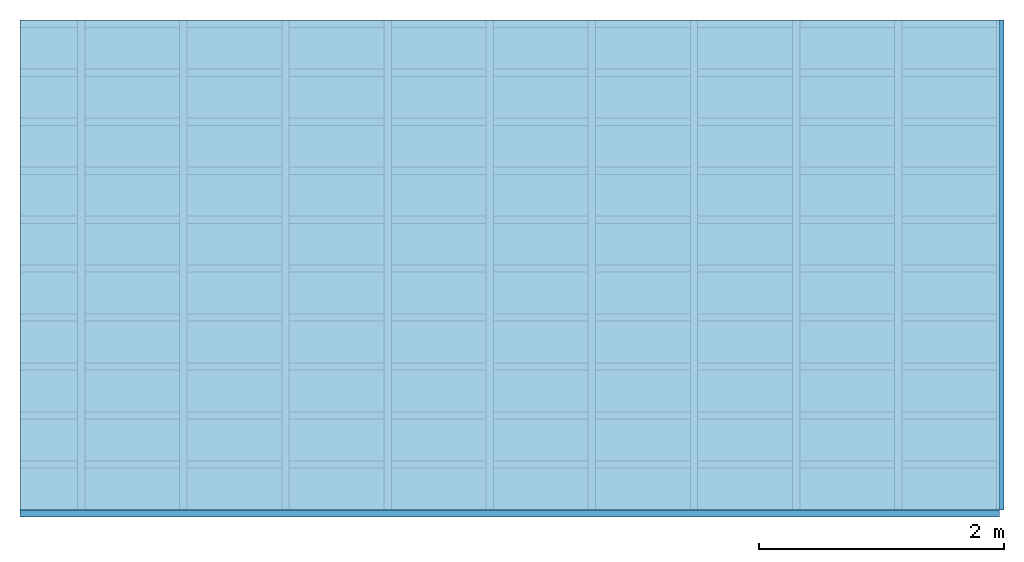
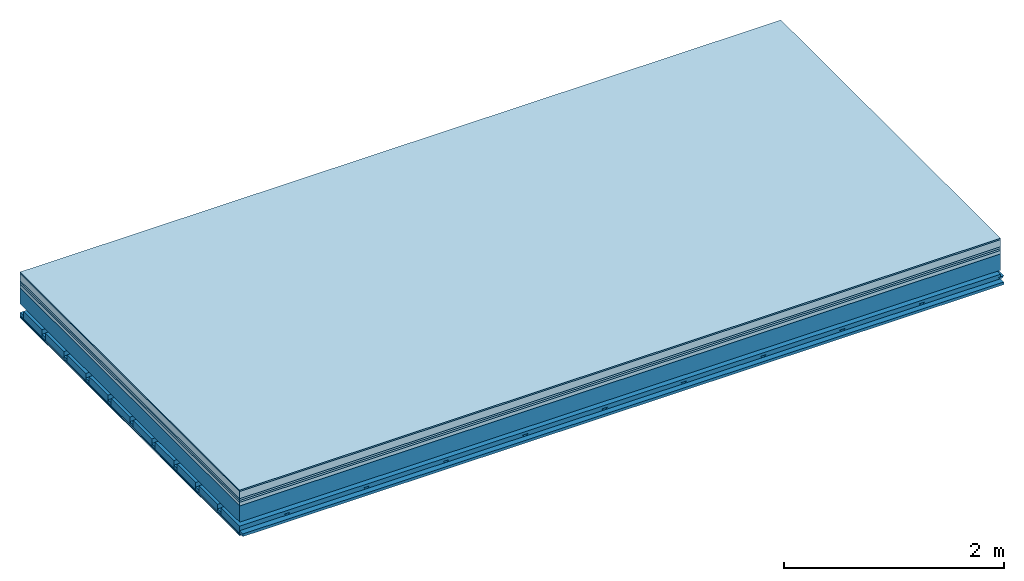
# One storey: 8 plates, 4 members, 1 element without a shape of its own.
"""IFC4 building model written with IfcOpenShell, lengths in metres."""

from ifc_helpers import new_model, si_unit, derived_unit, direction, frame, frame_2d, origin, origin_with_axes, place, context, project, spatial, polyline, rectangle, outline, extrude, material, layer, layer_set, type_object, element, aggregate, save


model = new_model("IFC4")

# Units and contexts
plan_context = context("Plan", 3, precision=1e-05, world=origin(), true_north=direction((0.0, 1.0)))
model_context = context("Model", 3, precision=1e-05, world=origin(), true_north=direction((0.0, 1.0)))
ifc_project = project(units=[si_unit("LENGTHUNIT", "METRE"), derived_unit("SOUNDPRESSUREUNIT", [(si_unit("PRESSUREUNIT", "PASCAL", prefix="MICRO"), 0)]), si_unit("ENERGYUNIT", "JOULE", prefix="MEGA"), si_unit("MASSUNIT", "GRAM", prefix="KILO"), derived_unit("THERMALTRANSMITTANCEUNIT", [(si_unit("POWERUNIT", "WATT"), 1), (si_unit("AREAUNIT", "SQUARE_METRE"), -1), (si_unit("THERMODYNAMICTEMPERATUREUNIT", "KELVIN"), -1)]), derived_unit("AREADENSITYUNIT", [(si_unit("MASSUNIT", "GRAM", prefix="KILO"), 1), (si_unit("AREAUNIT", "SQUARE_METRE"), -1)]), derived_unit("USERDEFINED", [(si_unit("ENERGYUNIT", "JOULE", prefix="MEGA"), 1), (si_unit("AREAUNIT", "SQUARE_METRE"), -1)])], contexts=[plan_context, model_context])

# Site, building, storey
site = spatial("IfcSite", under=ifc_project)
building_placement = place(None, origin())
building = spatial("IfcBuilding", under=site, at=building_placement)
storey_placement = place(building_placement, origin())
storey = spatial("IfcBuildingStorey", under=building, at=storey_placement)

# Slab, members, plates
ifc_material_1 = material(Category="11.013")
ifc_layer_1 = layer(ifc_material_1, 0.015, Name="Flooring")
ifc_material_2 = material(Name="Cement screed", Category="04.006")
ifc_layer_2 = layer(ifc_material_2, 0.08, Name="On-material")
ifc_material_3 = material(Name="Wood fiber generic product", Category="10.009")
ifc_layer_3 = layer(ifc_material_3, 0.02, Name="Impact sound insulation")
ifc_material_4 = material(Category="10.004")
ifc_layer_4 = layer(ifc_material_4, 0.02, Name="Additional insulation")
ifc_material_5 = material(Name="Garden plates", Category="02.007")
ifc_layer_5 = layer(ifc_material_5, 0.04, Name="on Supporting structure")
ifc_material_6 = material(Name="no composite action")
ifc_layer_6 = layer(ifc_material_6, 0.0, Name="Bond")
ifc_layer_7 = layer(None, 0.18, Name="Supporting structure")
ifc_layer_8 = layer(ifc_material_6, 0.0, Name="Bond")
ifc_layer_9 = layer(None, 0.095, Name="Coupling")
ifc_layer_10 = layer(None, 0.03, Name="Battens / profiles")
ifc_material_7 = material(Name="Plasterboard type A", Category="03.008")
ifc_layer_11 = layer(ifc_material_7, 0.0125, Name="Ceiling covering 1st layer")
ifc_layer_12 = layer(ifc_material_7, 0.0125, Name="Ceiling covering layer 2")
ifc_material_8 = material(Category="04.001")
ifc_layer_13 = layer(ifc_material_8, 0.003, Name="Surface / treatment")
ifc_layer_set = layer_set([ifc_layer_1, ifc_layer_2, ifc_layer_3, ifc_layer_4, ifc_layer_5, ifc_layer_6, ifc_layer_7, ifc_layer_8, ifc_layer_9, ifc_layer_10, ifc_layer_11, ifc_layer_12, ifc_layer_13])
slab_type = type_object("IfcSlabType", Name="A2171", PredefinedType="NOTDEFINED", material=ifc_layer_set)
slab_placement = place(None, frame((0.0, 0.0, 0.0), z_axis=(0.0, 0.0, -1.0), x_axis=(1.0, 0.0, 0.0)))
slab = element("IfcSlab", 1, at=slab_placement, inside=storey, type_object=slab_type, material=ifc_layer_set, Name="Slab #1")
ifc_material_9 = material(Name="Solid timber panel")
member_1_placement = place(slab_placement, origin())
member_1 = element("IfcMember", 2, at=member_1_placement, material=ifc_material_9, Name="Supporting structure", context=plan_context, shape_type="SweptSolid", body=[
    extrude(rectangle(XDim=1.0, YDim=0.18, at=frame_2d((0.5, 0.09), x_axis=(1.0, 0.0))), frame((0.0, 4.0, 0.175), z_axis=(0.0, -1.0, 0.0), x_axis=(1.0, 0.0, 0.0)), (0.0, 0.0, 1.0), 4.0),
    extrude(rectangle(XDim=1.0, YDim=0.18, at=frame_2d((0.5, 0.09), x_axis=(1.0, 0.0))), frame((1.0, 4.0, 0.175), z_axis=(0.0, -1.0, 0.0), x_axis=(1.0, 0.0, 0.0)), (0.0, 0.0, 1.0), 4.0),
    extrude(rectangle(XDim=1.0, YDim=0.18, at=frame_2d((0.5, 0.09), x_axis=(1.0, 0.0))), frame((2.0, 4.0, 0.175), z_axis=(0.0, -1.0, 0.0), x_axis=(1.0, 0.0, 0.0)), (0.0, 0.0, 1.0), 4.0),
    extrude(rectangle(XDim=1.0, YDim=0.18, at=frame_2d((0.5, 0.09), x_axis=(1.0, 0.0))), frame((3.0, 4.0, 0.175), z_axis=(0.0, -1.0, 0.0), x_axis=(1.0, 0.0, 0.0)), (0.0, 0.0, 1.0), 4.0),
    extrude(rectangle(XDim=1.0, YDim=0.18, at=frame_2d((0.5, 0.09), x_axis=(1.0, 0.0))), frame((4.0, 4.0, 0.175), z_axis=(0.0, -1.0, 0.0), x_axis=(1.0, 0.0, 0.0)), (0.0, 0.0, 1.0), 4.0),
    extrude(rectangle(XDim=1.0, YDim=0.18, at=frame_2d((0.5, 0.09), x_axis=(1.0, 0.0))), frame((5.0, 4.0, 0.175), z_axis=(0.0, -1.0, 0.0), x_axis=(1.0, 0.0, 0.0)), (0.0, 0.0, 1.0), 4.0),
    extrude(rectangle(XDim=1.0, YDim=0.18, at=frame_2d((0.5, 0.09), x_axis=(1.0, 0.0))), frame((6.0, 4.0, 0.175), z_axis=(0.0, -1.0, 0.0), x_axis=(1.0, 0.0, 0.0)), (0.0, 0.0, 1.0), 4.0),
    extrude(rectangle(XDim=1.0, YDim=0.18, at=frame_2d((0.5, 0.09), x_axis=(1.0, 0.0))), frame((7.0, 4.0, 0.175), z_axis=(0.0, -1.0, 0.0), x_axis=(1.0, 0.0, 0.0)), (0.0, 0.0, 1.0), 4.0),
])
ifc_material_10 = material()
member_2_placement = place(slab_placement, origin())
member_2 = element("IfcMember", 3, at=member_2_placement, material=ifc_material_10, Name="Coupling", context=plan_context, shape_type="SweptSolid", body=[
    extrude(outline(polyline([(0.0, 0.0), (0.06, 0.0), (0.04, 0.02), (0.02, 0.02), (0.0, 0.0)])), frame((0.47, 4.0, 0.43), z_axis=(0.0, -1.0, 0.0), x_axis=(1.0, 0.0, 0.0)), (0.0, 0.0, 1.0), 4.0),
    extrude(outline(polyline([(0.0, 0.0), (0.06, 0.0), (0.04, 0.02), (0.02, 0.02), (0.0, 0.0)])), frame((1.304, 4.0, 0.43), z_axis=(0.0, -1.0, 0.0), x_axis=(1.0, 0.0, 0.0)), (0.0, 0.0, 1.0), 4.0),
    extrude(outline(polyline([(0.0, 0.0), (0.06, 0.0), (0.04, 0.02), (0.02, 0.02), (0.0, 0.0)])), frame((2.138, 4.0, 0.43), z_axis=(0.0, -1.0, 0.0), x_axis=(1.0, 0.0, 0.0)), (0.0, 0.0, 1.0), 4.0),
    extrude(outline(polyline([(0.0, 0.0), (0.06, 0.0), (0.04, 0.02), (0.02, 0.02), (0.0, 0.0)])), frame((2.972, 4.0, 0.43), z_axis=(0.0, -1.0, 0.0), x_axis=(1.0, 0.0, 0.0)), (0.0, 0.0, 1.0), 4.0),
    extrude(outline(polyline([(0.0, 0.0), (0.06, 0.0), (0.04, 0.02), (0.02, 0.02), (0.0, 0.0)])), frame((3.806, 4.0, 0.43), z_axis=(0.0, -1.0, 0.0), x_axis=(1.0, 0.0, 0.0)), (0.0, 0.0, 1.0), 4.0),
    extrude(outline(polyline([(0.0, 0.0), (0.06, 0.0), (0.04, 0.02), (0.02, 0.02), (0.0, 0.0)])), frame((4.64, 4.0, 0.43), z_axis=(0.0, -1.0, 0.0), x_axis=(1.0, 0.0, 0.0)), (0.0, 0.0, 1.0), 4.0),
    extrude(outline(polyline([(0.0, 0.0), (0.06, 0.0), (0.04, 0.02), (0.02, 0.02), (0.0, 0.0)])), frame((5.474, 4.0, 0.43), z_axis=(0.0, -1.0, 0.0), x_axis=(1.0, 0.0, 0.0)), (0.0, 0.0, 1.0), 4.0),
    extrude(outline(polyline([(0.0, 0.0), (0.06, 0.0), (0.04, 0.02), (0.02, 0.02), (0.0, 0.0)])), frame((6.308, 4.0, 0.43), z_axis=(0.0, -1.0, 0.0), x_axis=(1.0, 0.0, 0.0)), (0.0, 0.0, 1.0), 4.0),
    extrude(outline(polyline([(0.0, 0.0), (0.06, 0.0), (0.04, 0.02), (0.02, 0.02), (0.0, 0.0)])), frame((7.142, 4.0, 0.43), z_axis=(0.0, -1.0, 0.0), x_axis=(1.0, 0.0, 0.0)), (0.0, 0.0, 1.0), 4.0),
    extrude(outline(polyline([(0.0, 0.0), (0.06, 0.0), (0.04, 0.02), (0.02, 0.02), (0.0, 0.0)])), frame((7.976, 4.0, 0.43), z_axis=(0.0, -1.0, 0.0), x_axis=(1.0, 0.0, 0.0)), (0.0, 0.0, 1.0), 4.0),
])
member_3_placement = place(slab_placement, origin())
member_3 = element("IfcMember", 4, at=member_3_placement, material=ifc_material_10, Name="Battens / profiles", context=plan_context, shape_type="SweptSolid", body=[
    extrude(rectangle(XDim=0.06, YDim=0.03, at=frame_2d((0.03, 0.015), x_axis=(1.0, 0.0))), frame((0.0, 0.0, 0.45), z_axis=(1.0, 0.0, 0.0), x_axis=(0.0, 1.0, 0.0)), (0.0, 0.0, 1.0), 8.0),
    extrude(rectangle(XDim=0.06, YDim=0.03, at=frame_2d((0.03, 0.015), x_axis=(1.0, 0.0))), frame((0.0, 0.4, 0.45), z_axis=(1.0, 0.0, 0.0), x_axis=(0.0, 1.0, 0.0)), (0.0, 0.0, 1.0), 8.0),
    extrude(rectangle(XDim=0.06, YDim=0.03, at=frame_2d((0.03, 0.015), x_axis=(1.0, 0.0))), frame((0.0, 0.8, 0.45), z_axis=(1.0, 0.0, 0.0), x_axis=(0.0, 1.0, 0.0)), (0.0, 0.0, 1.0), 8.0),
    extrude(rectangle(XDim=0.06, YDim=0.03, at=frame_2d((0.03, 0.015), x_axis=(1.0, 0.0))), frame((0.0, 1.2, 0.45), z_axis=(1.0, 0.0, 0.0), x_axis=(0.0, 1.0, 0.0)), (0.0, 0.0, 1.0), 8.0),
    extrude(rectangle(XDim=0.06, YDim=0.03, at=frame_2d((0.03, 0.015), x_axis=(1.0, 0.0))), frame((0.0, 1.6, 0.45), z_axis=(1.0, 0.0, 0.0), x_axis=(0.0, 1.0, 0.0)), (0.0, 0.0, 1.0), 8.0),
    extrude(rectangle(XDim=0.06, YDim=0.03, at=frame_2d((0.03, 0.015), x_axis=(1.0, 0.0))), frame((0.0, 2.0, 0.45), z_axis=(1.0, 0.0, 0.0), x_axis=(0.0, 1.0, 0.0)), (0.0, 0.0, 1.0), 8.0),
    extrude(rectangle(XDim=0.06, YDim=0.03, at=frame_2d((0.03, 0.015), x_axis=(1.0, 0.0))), frame((0.0, 2.4, 0.45), z_axis=(1.0, 0.0, 0.0), x_axis=(0.0, 1.0, 0.0)), (0.0, 0.0, 1.0), 8.0),
    extrude(rectangle(XDim=0.06, YDim=0.03, at=frame_2d((0.03, 0.015), x_axis=(1.0, 0.0))), frame((0.0, 2.8, 0.45), z_axis=(1.0, 0.0, 0.0), x_axis=(0.0, 1.0, 0.0)), (0.0, 0.0, 1.0), 8.0),
    extrude(rectangle(XDim=0.06, YDim=0.03, at=frame_2d((0.03, 0.015), x_axis=(1.0, 0.0))), frame((0.0, 3.2, 0.45), z_axis=(1.0, 0.0, 0.0), x_axis=(0.0, 1.0, 0.0)), (0.0, 0.0, 1.0), 8.0),
    extrude(rectangle(XDim=0.06, YDim=0.03, at=frame_2d((0.03, 0.015), x_axis=(1.0, 0.0))), frame((0.0, 3.6, 0.45), z_axis=(1.0, 0.0, 0.0), x_axis=(0.0, 1.0, 0.0)), (0.0, 0.0, 1.0), 8.0),
    extrude(rectangle(XDim=0.06, YDim=0.03, at=frame_2d((0.03, 0.015), x_axis=(1.0, 0.0))), frame((0.0, 4.0, 0.45), z_axis=(1.0, 0.0, 0.0), x_axis=(0.0, 1.0, 0.0)), (0.0, 0.0, 1.0), 8.0),
])
ifc_material_11 = material()
member_4_placement = place(slab_placement, origin())
member_4 = element("IfcMember", 5, at=member_4_placement, material=ifc_material_11, Name="Cavity", context=plan_context, shape_type="SweptSolid", body=[
    extrude(rectangle(XDim=0.34, YDim=0.08, at=frame_2d((0.17, 0.04), x_axis=(1.0, 0.0))), frame((0.0, 0.06, 0.4), z_axis=(1.0, 0.0, 0.0), x_axis=(0.0, 1.0, 0.0)), (0.0, 0.0, 1.0), 8.0),
    extrude(rectangle(XDim=0.34, YDim=0.08, at=frame_2d((0.17, 0.04), x_axis=(1.0, 0.0))), frame((0.0, 0.46, 0.4), z_axis=(1.0, 0.0, 0.0), x_axis=(0.0, 1.0, 0.0)), (0.0, 0.0, 1.0), 8.0),
    extrude(rectangle(XDim=0.34, YDim=0.08, at=frame_2d((0.17, 0.04), x_axis=(1.0, 0.0))), frame((0.0, 0.86, 0.4), z_axis=(1.0, 0.0, 0.0), x_axis=(0.0, 1.0, 0.0)), (0.0, 0.0, 1.0), 8.0),
    extrude(rectangle(XDim=0.34, YDim=0.08, at=frame_2d((0.17, 0.04), x_axis=(1.0, 0.0))), frame((0.0, 1.26, 0.4), z_axis=(1.0, 0.0, 0.0), x_axis=(0.0, 1.0, 0.0)), (0.0, 0.0, 1.0), 8.0),
    extrude(rectangle(XDim=0.34, YDim=0.08, at=frame_2d((0.17, 0.04), x_axis=(1.0, 0.0))), frame((0.0, 1.66, 0.4), z_axis=(1.0, 0.0, 0.0), x_axis=(0.0, 1.0, 0.0)), (0.0, 0.0, 1.0), 8.0),
    extrude(rectangle(XDim=0.34, YDim=0.08, at=frame_2d((0.17, 0.04), x_axis=(1.0, 0.0))), frame((0.0, 2.06, 0.4), z_axis=(1.0, 0.0, 0.0), x_axis=(0.0, 1.0, 0.0)), (0.0, 0.0, 1.0), 8.0),
    extrude(rectangle(XDim=0.34, YDim=0.08, at=frame_2d((0.17, 0.04), x_axis=(1.0, 0.0))), frame((0.0, 2.46, 0.4), z_axis=(1.0, 0.0, 0.0), x_axis=(0.0, 1.0, 0.0)), (0.0, 0.0, 1.0), 8.0),
    extrude(rectangle(XDim=0.34, YDim=0.08, at=frame_2d((0.17, 0.04), x_axis=(1.0, 0.0))), frame((0.0, 2.86, 0.4), z_axis=(1.0, 0.0, 0.0), x_axis=(0.0, 1.0, 0.0)), (0.0, 0.0, 1.0), 8.0),
    extrude(rectangle(XDim=0.34, YDim=0.08, at=frame_2d((0.17, 0.04), x_axis=(1.0, 0.0))), frame((0.0, 3.26, 0.4), z_axis=(1.0, 0.0, 0.0), x_axis=(0.0, 1.0, 0.0)), (0.0, 0.0, 1.0), 8.0),
    extrude(rectangle(XDim=0.34, YDim=0.08, at=frame_2d((0.17, 0.04), x_axis=(1.0, 0.0))), frame((0.0, 3.66, 0.4), z_axis=(1.0, 0.0, 0.0), x_axis=(0.0, 1.0, 0.0)), (0.0, 0.0, 1.0), 8.0),
])
plate_1_placement = place(slab_placement, origin())
plate_1 = element("IfcPlate", 6, at=plate_1_placement, material=ifc_material_1, Name="Flooring", context=plan_context, shape_type="SweptSolid", body=[
    extrude(rectangle(XDim=8.0, YDim=4.0, at=frame_2d((4.0, 2.0), x_axis=(1.0, 0.0))), origin_with_axes(), (0.0, 0.0, 1.0), 0.015),
])
plate_2_placement = place(slab_placement, origin())
plate_2 = element("IfcPlate", 7, at=plate_2_placement, material=ifc_material_2, Name="On-material", context=plan_context, shape_type="SweptSolid", body=[
    extrude(rectangle(XDim=8.0, YDim=4.0, at=frame_2d((4.0, 2.0), x_axis=(1.0, 0.0))), frame((0.0, 0.0, 0.015), z_axis=(0.0, 0.0, 1.0), x_axis=(1.0, 0.0, 0.0)), (0.0, 0.0, 1.0), 0.08),
])
plate_3_placement = place(slab_placement, origin())
plate_3 = element("IfcPlate", 8, at=plate_3_placement, material=ifc_material_3, Name="Impact sound insulation", context=plan_context, shape_type="SweptSolid", body=[
    extrude(rectangle(XDim=8.0, YDim=4.0, at=frame_2d((4.0, 2.0), x_axis=(1.0, 0.0))), frame((0.0, 0.0, 0.095), z_axis=(0.0, 0.0, 1.0), x_axis=(1.0, 0.0, 0.0)), (0.0, 0.0, 1.0), 0.02),
])
plate_4_placement = place(slab_placement, origin())
plate_4 = element("IfcPlate", 9, at=plate_4_placement, material=ifc_material_4, Name="Additional insulation", context=plan_context, shape_type="SweptSolid", body=[
    extrude(rectangle(XDim=8.0, YDim=4.0, at=frame_2d((4.0, 2.0), x_axis=(1.0, 0.0))), frame((0.0, 0.0, 0.115), z_axis=(0.0, 0.0, 1.0), x_axis=(1.0, 0.0, 0.0)), (0.0, 0.0, 1.0), 0.02),
])
plate_5_placement = place(slab_placement, origin())
plate_5 = element("IfcPlate", 10, at=plate_5_placement, material=ifc_material_5, Name="on Supporting structure", context=plan_context, shape_type="SweptSolid", body=[
    extrude(rectangle(XDim=8.0, YDim=4.0, at=frame_2d((4.0, 2.0), x_axis=(1.0, 0.0))), frame((0.0, 0.0, 0.135), z_axis=(0.0, 0.0, 1.0), x_axis=(1.0, 0.0, 0.0)), (0.0, 0.0, 1.0), 0.04),
])
plate_6_placement = place(slab_placement, origin())
plate_6 = element("IfcPlate", 11, at=plate_6_placement, material=ifc_material_7, Name="Ceiling covering 1st layer", context=plan_context, shape_type="SweptSolid", body=[
    extrude(rectangle(XDim=8.0, YDim=4.0, at=frame_2d((4.0, 2.0), x_axis=(1.0, 0.0))), frame((0.0, 0.0, 0.48), z_axis=(0.0, 0.0, 1.0), x_axis=(1.0, 0.0, 0.0)), (0.0, 0.0, 1.0), 0.0125),
])
plate_7_placement = place(slab_placement, origin())
plate_7 = element("IfcPlate", 12, at=plate_7_placement, material=ifc_material_7, Name="Ceiling covering layer 2", context=plan_context, shape_type="SweptSolid", body=[
    extrude(rectangle(XDim=8.0, YDim=4.0, at=frame_2d((4.0, 2.0), x_axis=(1.0, 0.0))), frame((0.0, 0.0, 0.4925), z_axis=(0.0, 0.0, 1.0), x_axis=(1.0, 0.0, 0.0)), (0.0, 0.0, 1.0), 0.0125),
])
plate_8_placement = place(slab_placement, origin())
plate_8 = element("IfcPlate", 13, at=plate_8_placement, material=ifc_material_8, Name="Surface / treatment", context=plan_context, shape_type="SweptSolid", body=[
    extrude(rectangle(XDim=8.0, YDim=4.0, at=frame_2d((4.0, 2.0), x_axis=(1.0, 0.0))), frame((0.0, 0.0, 0.505), z_axis=(0.0, 0.0, 1.0), x_axis=(1.0, 0.0, 0.0)), (0.0, 0.0, 1.0), 0.003),
])
aggregate(slab, [plate_1, plate_2, plate_3, plate_4, plate_5, member_1, member_2, member_3, member_4, plate_6, plate_7, plate_8])

save(model, "model.ifc")
